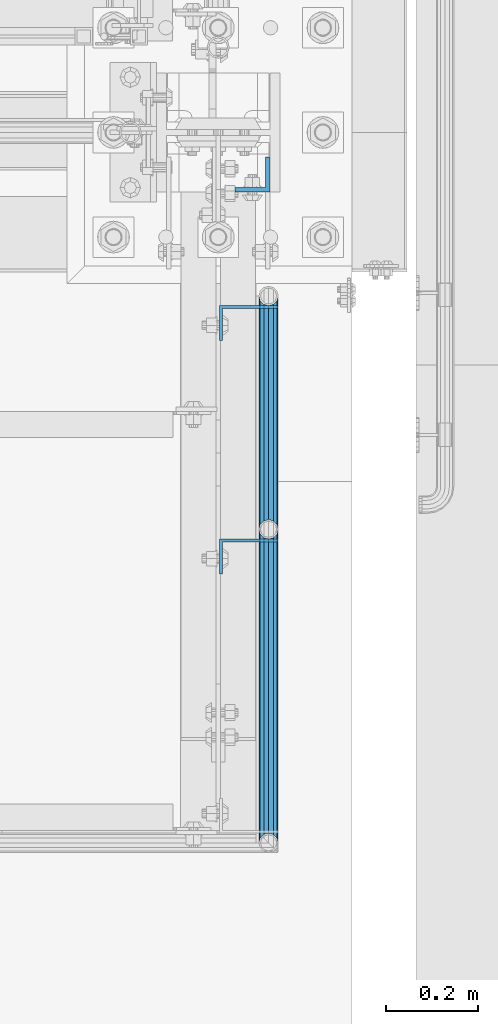
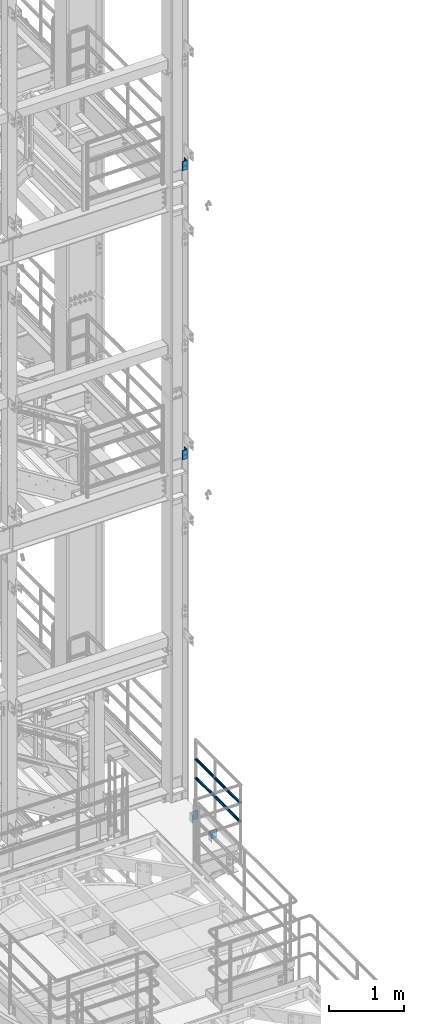
# One storey, part 1213 of 1876: 8 beams, 3 elements without a shape of their own.
"""IFC2X3 building model written with IfcOpenShell, lengths in millimetres."""

from ifc_helpers import new_model, si_unit, frame, origin_with_axes, place, context, subcontext, project, spatial, faceted_brep, material, type_object, element, aggregate, save


model = new_model("IFC2X3")

# Units and contexts
model_context = context("Model", 3, precision=1e-05, world=origin_with_axes())
body_context = subcontext(model_context, "Body", "Model", "MODEL_VIEW")
ifc_project = project(units=[si_unit("LENGTHUNIT", "METRE", prefix="MILLI"), si_unit("AREAUNIT", "SQUARE_METRE"), si_unit("VOLUMEUNIT", "CUBIC_METRE"), si_unit("MASSUNIT", "GRAM", prefix="KILO"), si_unit("TIMEUNIT", "SECOND"), si_unit("PLANEANGLEUNIT", "RADIAN"), si_unit("SOLIDANGLEUNIT", "STERADIAN"), si_unit("THERMODYNAMICTEMPERATUREUNIT", "DEGREE_CELSIUS"), si_unit("LUMINOUSINTENSITYUNIT", "LUMEN")], contexts=[model_context])

# Site, building, storey
site_placement = place(None, origin_with_axes())
site = spatial("IfcSite", under=ifc_project, at=site_placement, CompositionType="ELEMENT")
building_placement = place(site_placement, origin_with_axes())
building = spatial("IfcBuilding", under=site, at=building_placement, Name="Undefined", CompositionType="ELEMENT")
storey_placement = place(building_placement, origin_with_axes())
storey = spatial("IfcBuildingStorey", under=building, at=storey_placement, Name="Undefined", CompositionType="ELEMENT", Elevation=0.0)

# Assembly, beams
assembly_1_placement = place(storey_placement, origin_with_axes())
assembly_1 = element("IfcElementAssembly", 1, at=assembly_1_placement, inside=storey, Name="HANDRAIL", AssemblyPlace="NOTDEFINED", PredefinedType="RIGID_FRAME")
ifc_material_1 = material()
beam_type_1 = type_object("IfcBeamType", Name="PIPE1-1/4STD", PredefinedType="NOTDEFINED")
beam_1_placement = place(assembly_1_placement, frame((7729.98590257769, -7978.68460156603, 8480.425), z_axis=(0.0, 0.0, 1.0), x_axis=(-5.69899999949814e-06, -0.999999999983761, 0.0)))
beam_1 = element("IfcBeam", 2, at=beam_1_placement, type_object=beam_type_1, material=ifc_material_1, Name="RAIL", ObjectType="PIPE1-1/4STD", context=body_context, shape_type="Brep", body=[
    faceted_brep([(666.489910955788, -10.5410000001375, 18.2575475625836), (666.489910955788, -10.5411042518572, 13.3998569750074), (666.013458496502, -8.76300000013907, 15.1779612267255), (663.665398445281, 3.81650352210272e-06, 17.5259999999998), (663.665398445281, 3.81650352210272e-06, 21.0820000000003), (666.013415939256, 8.76299999985986, 15.1779612267255), (666.489790809468, 10.5408957477948, 13.4000654787906), (666.48979080947, 10.5409999998592, 18.2575475625836), (684.747398449792, 21.081999999853, 0.0), (674.206294395322, 18.2575475624399, 10.5409999999993), (674.206294395322, 18.2575475624399, -10.5409999999993), (671.126803435287, 15.1779612265827, 8.76300000000083), (673.474815445768, 17.525999999857, 0.0), (671.126803435287, 15.1779612265827, -8.76300000000083), (666.489790809468, 10.5408957477948, -13.4000654787906), (666.48979080947, 10.5409999998592, -18.2575475625836), (666.013415939256, 8.76299999985986, -15.1779612267255), (663.665398445259, -1.40062184073031e-10, -17.5259999999998), (663.665398445259, -1.40062184073031e-10, -21.0820000000003), (666.489910955788, -10.5411042518572, -13.3998569750074), (666.489910955788, -10.5410000001375, -18.2575475625836), (666.013458496502, -8.76300000013907, -15.1779612267255), (684.74751859123, -21.08200020192, 0.0), (674.20650249485, -18.2575475627227, -10.5409999999993), (674.20650249485, -18.2575475627227, 10.5409999999993), (671.126820781994, -15.1779612268656, -8.76300000000083), (673.474886318365, -17.5260000001399, 0.0), (671.126820781994, -15.1779612268656, 8.76300000000083), (10.541104046074, -18.2575475625827, -10.5409999999993), (18.2576076319265, -10.5410000000002, -18.2575475625836), (9.09494701772928e-13, 21.0820000000003, 0.0), (10.5408959465467, 18.2575475625799, -10.5409999999993), (10.5408959465467, 18.2575475625799, 10.5409999999993), (18.2574874856082, 10.5409999999965, 18.2575475625836), (21.0819999961368, 0.000120148651149066, 21.0820000000003), (18.2574874856082, 10.5409999999965, -18.2575475625836), (21.0819999999985, 0.0, -21.0819999999985), (21.0819999999985, 0.0, -17.5259999999998), (18.2576076319265, -10.5408959477281, -13.4000652789982), (18.7339612267233, -8.76300000000083, -15.1779612267255), (18.7339612267251, 8.76299999999901, -15.1779612267255), (18.2574874856082, 10.5411040519239, -13.3998571747998), (13.6205863358573, 15.1779612267255, -8.76299999999901), (11.2725475625839, 17.5259999999998, 0.0), (13.6205863358573, 15.1779612267255, 8.76300000000083), (18.2574874856082, 10.5411040519239, 13.3998571747998), (18.7339612267251, 8.76299999999901, 15.1779612267273), (21.0819999961368, 0.000120148651149066, 17.5259999999998), (18.7339612267233, -8.76300000000083, 15.1779612267273), (18.2576076319265, -10.5408959477281, 13.4000652789982), (18.2576076319265, -10.5410000000002, 18.2575475625836), (10.541104046074, -18.2575475625827, 10.5409999999993), (9.09494701772928e-13, -21.0820000000003, 0.0), (13.6205863358537, -15.1779612267255, 8.76300000000083), (11.2725475625793, -17.5259999999998, 0.0), (13.6205863358537, -15.1779612267255, -8.76299999999901)], [[[0, 1, 2, 3, 4]], [[4, 3, 5, 6, 7]], [[8, 9, 10]], [[7, 6, 11, 12, 13, 14, 15, 10, 9]], [[16, 17, 18, 15, 14]], [[19, 20, 18, 17, 21]], [[22, 23, 24]], [[24, 23, 20, 19, 25, 26, 27, 1, 0]], [[28, 29, 20, 23]], [[30, 31, 32]], [[33, 34, 4, 7]], [[32, 33, 7, 9]], [[30, 32, 9, 8]], [[31, 30, 8, 10]], [[35, 31, 10, 15]], [[36, 35, 15, 18]], [[29, 36, 18, 20]], [[37, 36, 29, 38, 39]], [[40, 41, 35, 36, 37]], [[32, 31, 35, 41, 42, 43, 44, 45, 33]], [[33, 45, 46, 47, 34]], [[34, 47, 48, 49, 50]], [[34, 50, 0, 4]], [[50, 51, 24, 0]], [[51, 52, 22, 24]], [[52, 28, 23, 22]], [[51, 28, 52]], [[50, 49, 53, 54, 55, 38, 29, 28, 51]], [[55, 54, 26, 25]], [[21, 39, 38, 55, 25, 19]], [[37, 39, 21, 17]], [[40, 37, 17, 16]], [[42, 41, 40, 16, 14, 13]], [[43, 42, 13, 12]], [[44, 43, 12, 11]], [[5, 46, 45, 44, 11, 6]], [[47, 46, 5, 3]], [[48, 47, 3, 2]], [[53, 49, 48, 2, 1, 27]], [[54, 53, 27, 26]]]),
])
beam_2_placement = place(assembly_1_placement, frame((7729.98199999801, -7469.18749923977, 8480.425), z_axis=(0.0, 0.0, 1.0), x_axis=(7.66000000052945e-06, -0.999999999970662, 0.0)))
beam_2 = element("IfcBeam", 3, at=beam_2_placement, type_object=beam_type_1, material=ifc_material_1, Name="RAIL", ObjectType="PIPE1-1/4STD", context=body_context, shape_type="Brep", body=[
    faceted_brep([(491.239474031809, -10.5410000000338, 18.2575475625836), (491.239474031809, -10.5408603126671, 13.400100914092), (490.76311239292, -8.76300000003357, 15.1779612267255), (488.415102338589, -6.97043560649035e-06, 17.5259999999998), (488.415102338589, -6.97043560649035e-06, 21.0820000000003), (490.763169828341, 8.76299999997082, 15.1779612267255), (491.239635519929, 10.5411396867239, 13.3998215399733), (491.239635519928, 10.5409999999711, 18.2575475625836), (509.497102341459, 21.0819999999721, 0.0), (498.956242191043, 18.2575475625554, 10.5409999999993), (498.956242191043, 18.2575475625554, -10.5409999999993), (495.876528096552, 15.1779612266982, 8.76300000000083), (498.224602842057, 17.5259999999726, 0.0), (495.876528096552, 15.1779612266982, -8.76300000000083), (491.239635519929, 10.5411396867239, -13.3998215399733), (491.239635519928, 10.5409999999711, -18.2575475625836), (490.763169828341, 8.76299999997082, -15.1779612267255), (488.415102338533, -3.18323145620525e-11, -17.5259999999998), (488.415102338533, -3.18323145620525e-11, -21.0820000000003), (491.239474031809, -10.5408603126671, -13.400100914092), (491.239474031809, -10.5410000000338, -18.2575475625836), (490.76311239292, -8.76300000003357, -15.1779612267255), (509.496940849805, -21.0820001651773, 0.0), (498.955962485416, -18.2575475626199, -10.5409999999993), (498.955962485416, -18.2575475626199, 10.5409999999993), (495.876503906061, -15.177961226761, -8.76300000000083), (498.224506707657, -17.5260000000362, 0.0), (495.876503906061, -15.177961226761, 8.76300000000083), (10.5408601441704, -18.257547562589, -10.5409999999993), (18.2574668152856, -10.5410000000047, -18.2575475625836), (9.09494701772928e-13, 21.0820000000003, 0.0), (10.541139849799, 18.2575475625872, -10.5409999999993), (10.541139849799, 18.2575475625872, 10.5409999999993), (18.2576283034059, 10.5410000000002, 18.2575475625836), (21.0819999966798, -0.000161486127581156, 21.0820000000003), (18.2576283034059, 10.5410000000002, -18.2575475625836), (21.0819999999985, 0.0, -21.0819999999985), (21.0819999999985, 0.0, -17.5259999999998), (18.2574668152856, -10.5411398505175, -13.3998213762134), (18.7339612267233, -8.76300000000083, -15.1779612267255), (18.7339612267251, 8.76299999999901, -15.1779612267255), (18.257628303405, 10.5408601488734, -13.400101077852), (13.6205863358573, 15.1779612267255, -8.76299999999901), (11.2725475625839, 17.5259999999998, 0.0), (13.6205863358573, 15.1779612267255, 8.76300000000083), (18.257628303405, 10.5408601488734, 13.400101077852), (18.7339612267251, 8.76299999999901, 15.1779612267273), (21.0819999966798, -0.000161486127581156, 17.5259999999998), (18.7339612267233, -8.76300000000083, 15.1779612267273), (18.2574668152856, -10.5411398505175, 13.3998213762134), (18.2574668152856, -10.5410000000047, 18.2575475625836), (10.5408601441704, -18.2575475625899, 10.5409999999993), (9.09494701772928e-13, -21.0820000000003, 0.0), (13.6205863358537, -15.1779612267255, 8.76300000000083), (11.2725475625793, -17.5259999999998, 0.0), (13.6205863358537, -15.1779612267255, -8.76299999999901)], [[[0, 1, 2, 3, 4]], [[4, 3, 5, 6, 7]], [[8, 9, 10]], [[7, 6, 11, 12, 13, 14, 15, 10, 9]], [[16, 17, 18, 15, 14]], [[19, 20, 18, 17, 21]], [[22, 23, 24]], [[24, 23, 20, 19, 25, 26, 27, 1, 0]], [[28, 29, 20, 23]], [[30, 31, 32]], [[33, 34, 4, 7]], [[32, 33, 7, 9]], [[30, 32, 9, 8]], [[31, 30, 8, 10]], [[35, 31, 10, 15]], [[36, 35, 15, 18]], [[29, 36, 18, 20]], [[37, 36, 29, 38, 39]], [[40, 41, 35, 36, 37]], [[32, 31, 35, 41, 42, 43, 44, 45, 33]], [[33, 45, 46, 47, 34]], [[34, 47, 48, 49, 50]], [[34, 50, 0, 4]], [[50, 51, 24, 0]], [[51, 52, 22, 24]], [[52, 28, 23, 22]], [[51, 28, 52]], [[50, 49, 53, 54, 55, 38, 29, 28, 51]], [[55, 54, 26, 25]], [[21, 39, 38, 55, 25, 19]], [[37, 39, 21, 17]], [[40, 37, 17, 16]], [[42, 41, 40, 16, 14, 13]], [[43, 42, 13, 12]], [[44, 43, 12, 11]], [[5, 46, 45, 44, 11, 6]], [[47, 46, 5, 3]], [[48, 47, 3, 2]], [[53, 49, 48, 2, 1, 27]], [[54, 53, 27, 26]]]),
])
beam_3_placement = place(assembly_1_placement, frame((7729.98199999888, -8663.43200000567, 8785.225), z_axis=(0.0, 0.0, -1.0), x_axis=(5.69899999950077e-06, 0.999999999983761, 0.0)))
beam_3 = element("IfcBeam", 4, at=beam_3_placement, type_object=beam_type_1, material=ifc_material_1, Name="RAIL", ObjectType="PIPE1-1/4STD", context=body_context, shape_type="Brep", body=[
    faceted_brep([(9.09494701772928e-13, 21.0820000000003, 0.0), (10.541139849799, 18.2575475625872, -10.5409999999993), (10.541139849799, 18.2575475625872, 10.5409999999993), (10.5408601441704, -18.2575475625899, 10.5409999999993), (10.5408601441704, -18.257547562589, -10.5409999999993), (9.09494701772928e-13, -21.0820000000003, 0.0), (18.2574668152856, -10.5410000000047, 18.2575475625836), (18.2574874947804, -10.5411040484551, 13.3998571782631), (13.6205863358537, -15.1779612267255, 8.76300000000083), (11.2725475625793, -17.5259999999998, 0.0), (13.6205863358537, -15.1779612267255, -8.76299999999901), (18.2574874947804, -10.5411040484551, -13.3998571782631), (18.2574668152856, -10.5410000000047, -18.2575475625836), (21.0819999999985, 0.0, -17.5259999999998), (21.0819999999985, 0.0, -21.0819999999985), (18.7339612267233, -8.76300000000083, -15.1779612267255), (18.7339612267251, 8.76299999999901, -15.1779612267255), (18.2576076411187, 10.5408959511969, -13.4000652755331), (18.2576283034059, 10.5410000000002, -18.2575475625836), (13.6205863358573, 15.1779612267255, -8.76299999999901), (11.2725475625839, 17.5259999999998, 0.0), (13.6205863358573, 15.1779612267255, 8.76300000000083), (18.2576076411187, 10.5408959511969, 13.4000652755331), (18.2576283034059, 10.5410000000002, 18.2575475625836), (18.7339612267251, 8.76299999999901, 15.1779612267273), (21.0819999966798, -0.000161486127581156, 17.5259999999998), (21.0819999966798, -0.000161486127581156, 21.0820000000003), (18.7339612267233, -8.76300000000083, 15.1779612267273), (684.747398449792, 21.081999999853, 0.0), (674.206502504047, 18.2575475627254, -10.5409999999993), (666.48991096498, 10.541000000143, -18.2575475625836), (684.747278307756, -21.0819997933095, 0.0), (674.206294404486, -18.2575475624362, -10.5409999999993), (674.206294404486, -18.2575475624362, 10.5409999999993), (666.489790818642, -10.5409999998546, 18.2575475625836), (666.489790818642, -10.5409999998537, -18.2575475625836), (663.665398445259, -1.40062184073031e-10, -21.0820000000003), (666.013415939256, 8.76299999985986, -15.1779612267255), (663.665398445259, -1.40062184073031e-10, -17.5259999999998), (666.48991096498, 10.5411042559153, -13.3998569709529), (666.489790818641, -10.5408957437357, -13.4000654828451), (666.013458496502, -8.76300000013907, -15.1779612267255), (671.126820781994, -15.1779612268656, -8.76300000000083), (673.474815458993, -17.5259999998525, 0.0), (671.126820781994, -15.1779612268656, 8.76300000000083), (666.489790818641, -10.5408957437357, 13.4000654828451), (666.013458496502, -8.76300000013907, 15.1779612267255), (663.665398445281, 3.81650352210272e-06, 17.5259999999998), (663.665398445281, 3.81650352210272e-06, 21.0820000000003), (666.48991096498, 10.541000000142, 18.2575475625836), (674.206502504047, 18.2575475627254, 10.5409999999993), (666.48991096498, 10.5411042559153, 13.3998569709529), (671.126803435287, 15.1779612265827, 8.76300000000083), (673.474886323502, 17.5260000001426, 0.0), (671.126803435287, 15.1779612265827, -8.76300000000083), (666.013415939256, 8.76299999985986, 15.1779612267255)], [[[0, 1, 2]], [[3, 4, 5]], [[6, 7, 8, 9, 10, 11, 12, 4, 3]], [[13, 14, 12, 11, 15]], [[16, 17, 18, 14, 13]], [[2, 1, 18, 17, 19, 20, 21, 22, 23]], [[23, 22, 24, 25, 26]], [[26, 25, 27, 7, 6]], [[28, 29, 1, 0]], [[29, 30, 18, 1]], [[31, 32, 33]], [[33, 34, 6, 3]], [[31, 33, 3, 5]], [[32, 31, 5, 4]], [[35, 32, 4, 12]], [[36, 35, 12, 14]], [[30, 36, 14, 18]], [[37, 38, 36, 30, 39]], [[40, 35, 36, 38, 41]], [[33, 32, 35, 40, 42, 43, 44, 45, 34]], [[34, 45, 46, 47, 48]], [[34, 48, 26, 6]], [[49, 50, 2, 23]], [[48, 49, 23, 26]], [[50, 28, 0, 2]], [[28, 50, 29]], [[49, 51, 52, 53, 54, 39, 30, 29, 50]], [[48, 47, 55, 51, 49]], [[55, 47, 25, 24]], [[21, 52, 51, 55, 24, 22]], [[53, 52, 21, 20]], [[54, 53, 20, 19]], [[37, 39, 54, 19, 17, 16]], [[16, 13, 38, 37]], [[13, 15, 41, 38]], [[10, 42, 40, 41, 15, 11]], [[43, 42, 10, 9]], [[44, 43, 9, 8]], [[46, 45, 44, 8, 7, 27]], [[47, 46, 27, 25]]]),
])
beam_4_placement = place(assembly_1_placement, frame((7729.98590257726, -7978.68460156697, 8785.225), z_axis=(0.0, 0.0, -1.0), x_axis=(-7.660000000533e-06, 0.999999999970662, 0.0)))
beam_4 = element("IfcBeam", 5, at=beam_4_placement, type_object=beam_type_1, material=ifc_material_1, Name="RAIL", ObjectType="PIPE1-1/4STD", context=body_context, shape_type="Brep", body=[
    faceted_brep([(9.09494701772928e-13, 21.0820000000003, 0.0), (10.5408959465467, 18.2575475625799, -10.5409999999993), (10.5408959465467, 18.2575475625799, 10.5409999999993), (10.541104046074, -18.2575475625827, 10.5409999999993), (10.541104046074, -18.2575475625827, -10.5409999999993), (9.09494701772928e-13, -21.0820000000003, 0.0), (18.2576076319265, -10.5410000000002, 18.2575475625836), (18.2576283105764, -10.5408601441168, 13.4001010826105), (13.6205863358537, -15.1779612267255, 8.76300000000083), (11.2725475625793, -17.5259999999998, 0.0), (13.6205863358537, -15.1779612267255, -8.76299999999901), (18.2576283105764, -10.5408601441168, -13.4001010826105), (18.2576076319265, -10.5410000000002, -18.2575475625836), (21.0819999999985, 0.0, -17.5259999999998), (21.0819999999985, 0.0, -21.0819999999985), (18.7339612267233, -8.76300000000083, -15.1779612267255), (18.7339612267251, 8.76299999999901, -15.1779612267255), (18.2574668224561, 10.5411398552742, -13.3998213714549), (18.2574874856082, 10.5409999999965, -18.2575475625836), (13.6205863358573, 15.1779612267255, -8.76299999999901), (11.2725475625839, 17.5259999999998, 0.0), (13.6205863358573, 15.1779612267255, 8.76300000000083), (18.2574668224561, 10.5411398552742, 13.3998213714549), (18.2574874856082, 10.5409999999965, 18.2575475625836), (18.7339612267251, 8.76299999999901, 15.1779612267273), (21.0819999961368, 0.000120148651149066, 17.5259999999998), (21.0819999961368, 0.000120148651149066, 21.0820000000003), (18.7339612267233, -8.76300000000083, 15.1779612267273), (509.497102341459, 21.0819999999721, 0.0), (498.955962492585, 18.257547562619, -10.5409999999993), (491.239474038979, 10.5410000000329, -18.2575475625836), (509.497263833216, -21.081999828848, 0.0), (498.956242198215, -18.2575475625563, -10.5409999999993), (498.956242198215, -18.2575475625563, 10.5409999999993), (491.239635527099, -10.540999999972, 18.2575475625836), (491.239635527099, -10.540999999972, -18.2575475625836), (488.415102338533, -3.18323145620525e-11, -21.0820000000003), (490.763112398817, 8.76300000003266, -15.1779612267255), (488.415102338533, -3.18323145620525e-11, -17.5259999999998), (491.23947403898, 10.5408603174237, -13.4001009093354), (491.239635527099, -10.5411396819673, -13.39982154473), (490.763169836788, -8.76299999997082, -15.1779612267255), (495.876503906061, -15.177961226761, -8.76300000000083), (498.224602853985, -17.5259999999726, 0.0), (495.876503906061, -15.177961226761, 8.76300000000083), (491.239635527099, -10.5411396819673, 13.39982154473), (490.763169836788, -8.76299999997082, 15.1779612267255), (488.415102338589, -6.97043560649035e-06, 17.5259999999998), (488.415102338589, -6.97043560649035e-06, 21.0820000000003), (491.239474038979, 10.5410000000329, 18.2575475625836), (498.955962492585, 18.257547562619, 10.5409999999993), (491.23947403898, 10.5408603174237, 13.4001009093354), (495.876528096552, 15.1779612266982, 8.76300000000083), (498.22450671007, 17.5260000000362, 0.0), (495.876528096552, 15.1779612266982, -8.76300000000083), (490.763112398817, 8.76300000003266, 15.1779612267255)], [[[0, 1, 2]], [[3, 4, 5]], [[6, 7, 8, 9, 10, 11, 12, 4, 3]], [[13, 14, 12, 11, 15]], [[16, 17, 18, 14, 13]], [[2, 1, 18, 17, 19, 20, 21, 22, 23]], [[23, 22, 24, 25, 26]], [[26, 25, 27, 7, 6]], [[28, 29, 1, 0]], [[29, 30, 18, 1]], [[31, 32, 33]], [[33, 34, 6, 3]], [[31, 33, 3, 5]], [[32, 31, 5, 4]], [[35, 32, 4, 12]], [[36, 35, 12, 14]], [[30, 36, 14, 18]], [[37, 38, 36, 30, 39]], [[40, 35, 36, 38, 41]], [[33, 32, 35, 40, 42, 43, 44, 45, 34]], [[34, 45, 46, 47, 48]], [[34, 48, 26, 6]], [[49, 50, 2, 23]], [[48, 49, 23, 26]], [[50, 28, 0, 2]], [[28, 50, 29]], [[49, 51, 52, 53, 54, 39, 30, 29, 50]], [[48, 47, 55, 51, 49]], [[55, 47, 25, 24]], [[21, 52, 51, 55, 24, 22]], [[53, 52, 21, 20]], [[54, 53, 20, 19]], [[37, 39, 54, 19, 17, 16]], [[38, 37, 16, 13]], [[41, 38, 13, 15]], [[10, 42, 40, 41, 15, 11]], [[43, 42, 10, 9]], [[44, 43, 9, 8]], [[46, 45, 44, 8, 7, 27]], [[47, 46, 27, 25]]]),
])
ifc_material_2 = material(Name="STEEL/A36")
beam_type_2 = type_object("IfcBeamType", Name="L5X3X1/4", PredefinedType="NOTDEFINED")
beam_5_placement = place(assembly_1_placement, frame((7686.675, -7528.36949923706, 7966.075), z_axis=(1.0, 0.0, 0.0), x_axis=(0.0, 0.0, -1.0)))
beam_5 = element("IfcBeam", 6, at=beam_5_placement, type_object=beam_type_2, material=ifc_material_2, Name="ANGLE", ObjectType="L5X3X1/4", context=body_context, shape_type="Brep", body=[
    faceted_brep([(0.0, 38.1000000000004, -63.5), (0.0, 38.1000000000004, 63.5), (139.7, 38.1000000000004, 63.5), (139.7, 38.1000000000004, -63.5), (0.0, 31.75, 63.5), (139.7, 31.75, 63.5), (0.0, 31.75, -57.1499999999996), (139.7, 31.75, -57.1499999999996), (0.0, -38.1000000000004, -57.1499999999996), (139.7, -38.1000000000004, -57.1499999999996), (0.0, -38.1000000000004, -63.5), (139.7, -38.1000000000004, -63.5)], [[[0, 1, 2, 3]], [[1, 4, 5, 2]], [[4, 6, 7, 5]], [[6, 8, 9, 7]], [[8, 10, 11, 9]], [[10, 0, 3, 11]], [[5, 7, 9, 11, 3, 2]], [[10, 8, 6, 4, 1, 0]]]),
])
beam_6_placement = place(assembly_1_placement, frame((7686.675, -8037.86660156251, 7966.075), z_axis=(1.0, 0.0, 0.0), x_axis=(0.0, 0.0, -1.0)))
beam_6 = element("IfcBeam", 7, at=beam_6_placement, type_object=beam_type_2, material=ifc_material_2, Name="ANGLE", ObjectType="L5X3X1/4", context=body_context, shape_type="Brep", body=[
    faceted_brep([(0.0, 38.1000000000004, -63.5), (0.0, 38.1000000000004, 63.5), (139.7, 38.1000000000004, 63.5), (139.7, 38.1000000000004, -63.5), (0.0, 31.75, 63.5), (139.7, 31.75, 63.5), (0.0, 31.75, -57.1499999999996), (139.7, 31.75, -57.1499999999996), (0.0, -38.1000000000004, -57.1499999999996), (139.7, -38.1000000000004, -57.1499999999996), (0.0, -38.1000000000004, -63.5), (139.7, -38.1000000000004, -63.5)], [[[0, 1, 2, 3]], [[1, 4, 5, 2]], [[4, 6, 7, 5]], [[6, 8, 9, 7]], [[8, 10, 11, 9]], [[10, 0, 3, 11]], [[5, 7, 9, 11, 3, 2]], [[10, 8, 6, 4, 1, 0]]]),
])
aggregate(assembly_1, [beam_5, beam_6, beam_1, beam_2, beam_3, beam_4])

# Assembly, beam
assembly_2_placement = place(storey_placement, origin_with_axes())
assembly_2 = element("IfcElementAssembly", 8, at=assembly_2_placement, inside=storey, Name="COLUMN", AssemblyPlace="NOTDEFINED", PredefinedType="RIGID_FRAME")
beam_type_3 = type_object("IfcBeamType", Name="L3X3X3/8", PredefinedType="NOTDEFINED")
beam_7_placement = place(assembly_2_placement, frame((7694.53692732052, -7204.07500000733, 13665.2), z_axis=(-1.0, 0.0, 0.0), x_axis=(0.0, 0.0, -1.0)))
beam_7 = element("IfcBeam", 9, at=beam_7_placement, type_object=beam_type_3, material=ifc_material_2, Name="ANGLE", ObjectType="L3X3X3/8", context=body_context, shape_type="Brep", body=[
    faceted_brep([(0.0, 38.1000000000004, -38.1), (0.0, 38.1000000000004, 38.1), (152.4, 38.1000000000004, 38.1), (152.4, 38.1000000000004, -38.1), (0.0, 28.5749999999998, 38.1), (152.4, 28.5749999999998, 38.1), (0.0, 28.5749999999998, -28.575), (152.4, 28.5749999999998, -28.575), (0.0, -38.1000000000004, -28.575), (152.4, -38.1000000000004, -28.575), (0.0, -38.1000000000004, -38.1), (152.4, -38.1000000000004, -38.1)], [[[0, 1, 2, 3]], [[1, 4, 5, 2]], [[4, 6, 7, 5]], [[6, 8, 9, 7]], [[8, 10, 11, 9]], [[10, 0, 3, 11]], [[5, 7, 9, 11, 3, 2]], [[10, 8, 6, 4, 1, 0]]]),
])
aggregate(assembly_2, [beam_7])

assembly_3_placement = place(storey_placement, origin_with_axes())
assembly_3 = element("IfcElementAssembly", 10, at=assembly_3_placement, inside=storey, Name="COLUMN", AssemblyPlace="NOTDEFINED", PredefinedType="RIGID_FRAME")
beam_8_placement = place(assembly_3_placement, frame((7694.53692732058, -7204.075, 18351.5), z_axis=(-1.0, 0.0, 0.0), x_axis=(0.0, 0.0, -1.0)))
beam_8 = element("IfcBeam", 11, at=beam_8_placement, type_object=beam_type_3, material=ifc_material_2, Name="ANGLE", ObjectType="L3X3X3/8", context=body_context, shape_type="Brep", body=[
    faceted_brep([(0.0, 38.1000000000004, -38.1), (0.0, 38.1000000000004, 38.1), (152.4, 38.1000000000004, 38.1), (152.4, 38.1000000000004, -38.1), (0.0, 28.5749999999998, 38.1), (152.4, 28.5749999999998, 38.1), (0.0, 28.5749999999998, -28.575), (152.4, 28.5749999999998, -28.575), (0.0, -38.1000000000004, -28.575), (152.4, -38.1000000000004, -28.575), (0.0, -38.1000000000004, -38.1), (152.4, -38.1000000000004, -38.1)], [[[0, 1, 2, 3]], [[1, 4, 5, 2]], [[4, 6, 7, 5]], [[6, 8, 9, 7]], [[8, 10, 11, 9]], [[10, 0, 3, 11]], [[5, 7, 9, 11, 3, 2]], [[10, 8, 6, 4, 1, 0]]]),
])
aggregate(assembly_3, [beam_8])

save(model, "model.ifc")
